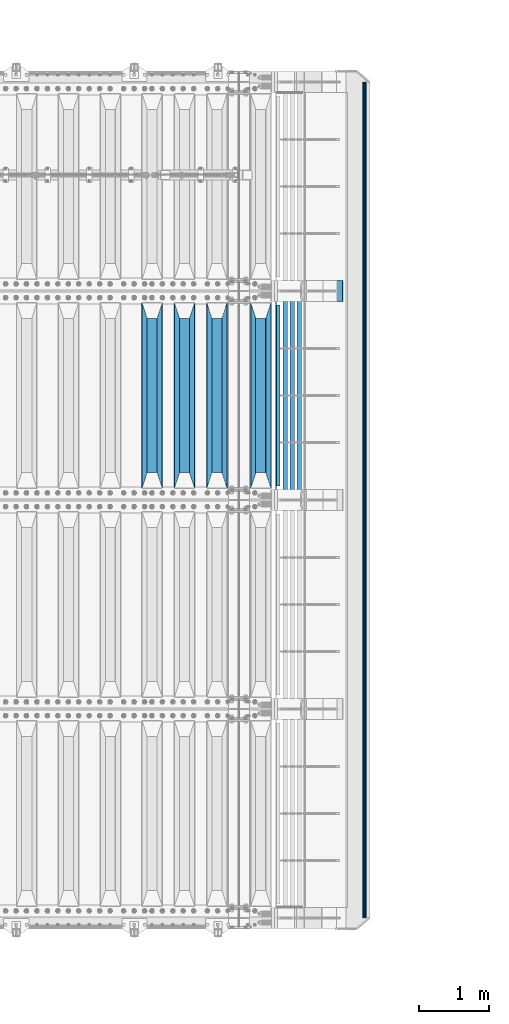
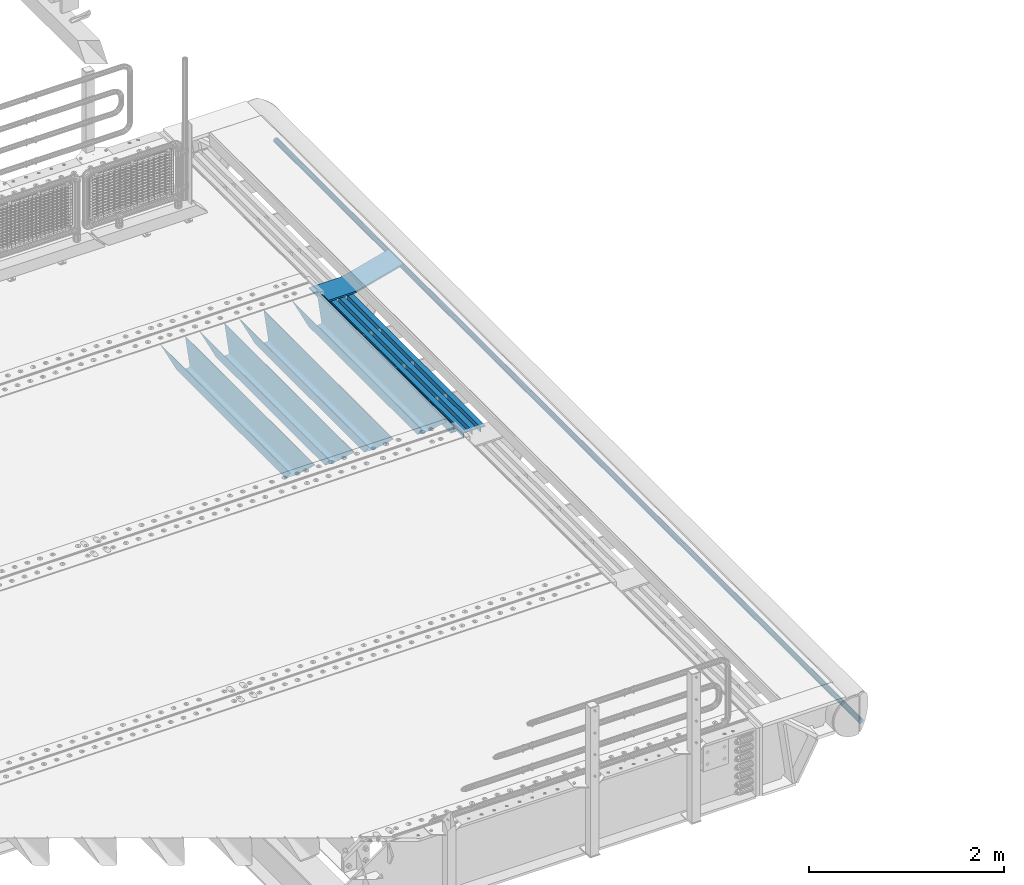
# One storey, part 133 of 257: 10 beams.
"""IFC2X3 building model written with IfcOpenShell, lengths in millimetres."""

from ifc_helpers import new_model, si_unit, frame, origin_with_axes, place, context, subcontext, project, spatial, faceted_brep, material, type_object, element, save


model = new_model("IFC2X3")

# Units and contexts
model_context = context("Model", 3, precision=1e-05, world=origin_with_axes())
body_context = subcontext(model_context, "Body", "Model", "MODEL_VIEW")
ifc_project = project(units=[si_unit("LENGTHUNIT", "METRE", prefix="MILLI"), si_unit("AREAUNIT", "SQUARE_METRE"), si_unit("VOLUMEUNIT", "CUBIC_METRE"), si_unit("MASSUNIT", "GRAM", prefix="KILO"), si_unit("TIMEUNIT", "SECOND"), si_unit("PLANEANGLEUNIT", "RADIAN"), si_unit("SOLIDANGLEUNIT", "STERADIAN"), si_unit("THERMODYNAMICTEMPERATUREUNIT", "DEGREE_CELSIUS"), si_unit("LUMINOUSINTENSITYUNIT", "LUMEN")], contexts=[model_context])

# Site, building, storey
site_placement = place(None, origin_with_axes())
site = spatial("IfcSite", under=ifc_project, at=site_placement, CompositionType="ELEMENT")
building_placement = place(site_placement, origin_with_axes())
building = spatial("IfcBuilding", under=site, at=building_placement, Name="Standard", CompositionType="ELEMENT")
storey_placement = place(building_placement, origin_with_axes())
storey = spatial("IfcBuildingStorey", under=building, at=storey_placement, Name="Undefined", CompositionType="ELEMENT", Elevation=0.0)

# Beams
ifc_material_1 = material(Name="STEEL/S355N")
beam_type_1 = type_object("IfcBeamType", PredefinedType="NOTDEFINED")
beam_1_placement = place(storey_placement, frame((59110.0, 6175.0, -115.0), z_axis=(0.0, 0.0, 1.0), x_axis=(0.0, 1.0, 0.0)))
element("IfcBeam", 1, at=beam_1_placement, inside=storey, type_object=beam_type_1, material=ifc_material_1, context=body_context, shape_type="Brep", body=[
    faceted_brep([(0.0, 150.0, 115.0), (0.0, 143.690000000002, 115.0), (2650.00000000297, 143.690000000002, 115.0), (2650.00000000297, 150.0, 115.0), (2650.00000000297, 142.059565218406, 110.0000000031), (2650.00000000297, 148.369565218403, 110.0000000031), (2441.90079219208, -80.1103600731149, -98.0992078077845), (2437.7588105432, -77.5672621345584, -102.241189456673), (2434.06523489746, -74.4080125315522, -105.934765102404), (2430.91086095089, -70.7102721255724, -109.089139048974), (2428.37322971128, -66.5649389910031, -111.626770288588), (2426.51472138055, -62.0739139532889, -113.485278619323), (2425.38102192091, -57.3475956567636, -114.618978078955), (2424.99999999987, -52.5021667386536, -115.0), (2424.99999999987, 52.5021667386536, -115.0), (2425.38102192091, 57.3475956567636, -114.618978078955), (2426.51472138055, 62.0739139532889, -113.485278619323), (2428.37322971128, 66.5649389910031, -111.626770288588), (2430.91086095089, 70.7102721255724, -109.089139048974), (2434.06523489746, 74.4080125315522, -105.934765102404), (2437.7588105432, 77.5672621345584, -102.241189456673), (2441.90079219208, 80.1103600731149, -98.0992078077846), (2446.38936140511, 81.9747917625791, -93.6106385947584), (2448.24948500409, 76.2713538057287, -91.7505149957729), (2444.62967112262, 74.76777986261, -95.3703288772456), (2441.28936334126, 72.7168944282894, -98.710636658607), (2438.31067330438, 70.1691124903809, -101.689326695487), (2435.76682334747, 67.1870637758839, -104.233176652398), (2433.72034654133, 63.8440531834931, -106.279653458539), (2432.22154950041, 60.2222587982324, -107.778450499454), (2431.30727574265, 56.4107117849126, -108.692724257221), (2430.99999999987, 52.5031078186876, -109.0), (2430.99999999987, -52.5031078186876, -109.0), (2431.30727574265, -56.4107117849126, -108.692724257221), (2432.22154950041, -60.2222587982324, -107.778450499454), (2433.72034654133, -63.8440531834931, -106.279653458539), (2435.76682334747, -67.1870637758839, -104.233176652398), (2438.31067330438, -70.1691124903809, -101.689326695487), (2441.28936334126, -72.7168944282894, -98.7106366586071), (2444.62967112262, -74.76777986261, -95.3703288772457), (2448.24948500409, -76.2713538057287, -91.7505149957729), (2650.00000000297, -142.059565218406, 110.0000000031), (2650.00000000297, -148.369565218403, 110.0000000031), (2446.38936140511, -81.9747917625791, -93.6106385947584), (2650.00000000297, -143.690000000002, 115.0), (2650.00000000297, -150.0, 115.0), (0.0, -143.690000000002, 115.0), (0.0, -150.0, 115.0), (0.0, -148.369565218258, 110.000000002662), (203.61063859742, -81.9747917625791, -93.6106385947584), (208.099207810447, -80.1103600731149, -98.0992078077845), (212.241189459335, -77.5672621345584, -102.241189456673), (215.934765105066, -74.4080125315522, -105.934765102404), (219.089139051636, -70.7102721255724, -109.089139048974), (221.626770291251, -66.5649389910031, -111.626770288588), (223.485278621985, -62.0739139532889, -113.485278619323), (224.618978081617, -57.3475956567636, -114.618978078955), (225.000000002662, -52.5021667386536, -115.0), (225.000000002662, 52.5021667386536, -115.0), (224.618978081617, 57.3475956567636, -114.618978078955), (223.485278621985, 62.0739139532889, -113.485278619323), (221.626770291251, 66.5649389910031, -111.626770288588), (219.089139051636, 70.7102721255724, -109.089139048974), (215.934765105066, 74.4080125315522, -105.934765102404), (212.241189459335, 77.5672621345584, -102.241189456673), (208.099207810447, 80.1103600731149, -98.0992078077846), (203.61063859742, 81.9747917625791, -93.6106385947584), (0.0, 148.369565218258, 110.000000002662), (0.0, 142.05956521826, 110.000000002662), (201.750514998435, 76.2713538057287, -91.7505149957729), (205.370328879908, 74.76777986261, -95.3703288772456), (208.710636661269, 72.7168944282894, -98.710636658607), (211.689326698149, 70.1691124903809, -101.689326695487), (214.233176655061, 67.1870637758839, -104.233176652398), (216.279653461201, 63.8440531834931, -106.279653458539), (217.778450502116, 60.2222587982324, -107.778450499454), (218.692724259884, 56.4107117849126, -108.692724257221), (219.000000002662, 52.5031078186876, -109.0), (219.000000002662, -52.5031078186876, -109.0), (218.692724259884, -56.4107117849126, -108.692724257221), (217.778450502116, -60.2222587982324, -107.778450499454), (216.279653461201, -63.8440531834931, -106.279653458539), (214.233176655061, -67.1870637758839, -104.233176652398), (211.689326698149, -70.1691124903809, -101.689326695487), (208.710636661269, -72.7168944282894, -98.7106366586071), (205.370328879908, -74.76777986261, -95.3703288772457), (201.750514998435, -76.2713538057287, -91.7505149957729), (0.0, -142.05956521826, 110.000000002662)], [[[0, 1, 2, 3]], [[3, 2, 4, 5]], [[6, 7, 8, 9, 10, 11, 12, 13, 14, 15, 16, 17, 18, 19, 20, 21, 22, 5, 4, 23, 24, 25, 26, 27, 28, 29, 30, 31, 32, 33, 34, 35, 36, 37, 38, 39, 40, 41, 42, 43]], [[44, 45, 42, 41]], [[46, 47, 45, 44]], [[43, 42, 45, 47, 48, 49]], [[6, 43, 49, 50]], [[7, 6, 50, 51]], [[8, 7, 51, 52]], [[9, 8, 52, 53]], [[10, 9, 53, 54]], [[11, 10, 54, 55]], [[12, 11, 55, 56]], [[13, 12, 56, 57]], [[14, 13, 57, 58]], [[15, 14, 58, 59]], [[16, 15, 59, 60]], [[17, 16, 60, 61]], [[18, 17, 61, 62]], [[19, 18, 62, 63]], [[20, 19, 63, 64]], [[21, 20, 64, 65]], [[22, 21, 65, 66]], [[0, 3, 5, 22, 66, 67]], [[1, 0, 67, 68]], [[23, 4, 2, 1, 68, 69]], [[24, 23, 69, 70]], [[25, 24, 70, 71]], [[26, 25, 71, 72]], [[27, 26, 72, 73]], [[28, 27, 73, 74]], [[29, 28, 74, 75]], [[30, 29, 75, 76]], [[31, 30, 76, 77]], [[32, 31, 77, 78]], [[33, 32, 78, 79]], [[34, 33, 79, 80]], [[35, 34, 80, 81]], [[36, 35, 81, 82]], [[37, 36, 82, 83]], [[38, 37, 83, 84]], [[39, 38, 84, 85]], [[40, 39, 85, 86]], [[46, 44, 41, 40, 86, 87]], [[47, 46, 87, 48]], [[86, 85, 84, 83, 82, 81, 80, 79, 78, 77, 76, 75, 74, 73, 72, 71, 70, 69, 68, 67, 66, 65, 64, 63, 62, 61, 60, 59, 58, 57, 56, 55, 54, 53, 52, 51, 50, 49, 48, 87]]]),
])
beam_2_placement = place(storey_placement, frame((58480.0, 6175.0, -115.0), z_axis=(0.0, 0.0, 1.0), x_axis=(0.0, 1.0, 0.0)))
element("IfcBeam", 2, at=beam_2_placement, inside=storey, type_object=beam_type_1, material=ifc_material_1, context=body_context, shape_type="Brep", body=[
    faceted_brep([(0.0, 150.0, 115.0), (0.0, 143.690000000002, 115.0), (2650.00000000297, 143.690000000002, 115.0), (2650.00000000297, 150.0, 115.0), (2650.00000000297, 142.059565218406, 110.0000000031), (2650.00000000297, 148.369565218403, 110.0000000031), (2441.90079219208, -80.1103600731149, -98.0992078077845), (2437.7588105432, -77.5672621345584, -102.241189456673), (2434.06523489746, -74.4080125315522, -105.934765102404), (2430.91086095089, -70.7102721255724, -109.089139048974), (2428.37322971128, -66.5649389910031, -111.626770288588), (2426.51472138055, -62.0739139532889, -113.485278619323), (2425.38102192091, -57.3475956567636, -114.618978078955), (2424.99999999987, -52.5021667386536, -115.0), (2424.99999999987, 52.5021667386536, -115.0), (2425.38102192091, 57.3475956567636, -114.618978078955), (2426.51472138055, 62.0739139532889, -113.485278619323), (2428.37322971128, 66.5649389910031, -111.626770288588), (2430.91086095089, 70.7102721255724, -109.089139048974), (2434.06523489746, 74.4080125315522, -105.934765102404), (2437.7588105432, 77.5672621345584, -102.241189456673), (2441.90079219208, 80.1103600731149, -98.0992078077846), (2446.38936140511, 81.9747917625791, -93.6106385947584), (2448.24948500409, 76.2713538057287, -91.7505149957729), (2444.62967112262, 74.76777986261, -95.3703288772456), (2441.28936334126, 72.7168944282894, -98.710636658607), (2438.31067330438, 70.1691124903809, -101.689326695487), (2435.76682334747, 67.1870637758839, -104.233176652398), (2433.72034654133, 63.8440531834931, -106.279653458539), (2432.22154950041, 60.2222587982324, -107.778450499454), (2431.30727574265, 56.4107117849126, -108.692724257221), (2430.99999999987, 52.5031078186876, -109.0), (2430.99999999987, -52.5031078186876, -109.0), (2431.30727574265, -56.4107117849126, -108.692724257221), (2432.22154950041, -60.2222587982324, -107.778450499454), (2433.72034654133, -63.8440531834931, -106.279653458539), (2435.76682334747, -67.1870637758839, -104.233176652398), (2438.31067330438, -70.1691124903809, -101.689326695487), (2441.28936334126, -72.7168944282894, -98.7106366586071), (2444.62967112262, -74.76777986261, -95.3703288772457), (2448.24948500409, -76.2713538057287, -91.7505149957729), (2650.00000000297, -142.059565218406, 110.0000000031), (2650.00000000297, -148.369565218403, 110.0000000031), (2446.38936140511, -81.9747917625791, -93.6106385947584), (2650.00000000297, -143.690000000002, 115.0), (2650.00000000297, -150.0, 115.0), (0.0, -143.690000000002, 115.0), (0.0, -150.0, 115.0), (0.0, -148.369565218258, 110.000000002662), (203.61063859742, -81.9747917625791, -93.6106385947584), (208.099207810447, -80.1103600731149, -98.0992078077845), (212.241189459335, -77.5672621345584, -102.241189456673), (215.934765105066, -74.4080125315522, -105.934765102404), (219.089139051636, -70.7102721255724, -109.089139048974), (221.626770291251, -66.5649389910031, -111.626770288588), (223.485278621985, -62.0739139532889, -113.485278619323), (224.618978081617, -57.3475956567636, -114.618978078955), (225.000000002662, -52.5021667386536, -115.0), (225.000000002662, 52.5021667386536, -115.0), (224.618978081617, 57.3475956567636, -114.618978078955), (223.485278621985, 62.0739139532889, -113.485278619323), (221.626770291251, 66.5649389910031, -111.626770288588), (219.089139051636, 70.7102721255724, -109.089139048974), (215.934765105066, 74.4080125315522, -105.934765102404), (212.241189459335, 77.5672621345584, -102.241189456673), (208.099207810447, 80.1103600731149, -98.0992078077846), (203.61063859742, 81.9747917625791, -93.6106385947584), (0.0, 148.369565218258, 110.000000002662), (0.0, 142.05956521826, 110.000000002662), (201.750514998435, 76.2713538057287, -91.7505149957729), (205.370328879908, 74.76777986261, -95.3703288772456), (208.710636661269, 72.7168944282894, -98.710636658607), (211.689326698149, 70.1691124903809, -101.689326695487), (214.233176655061, 67.1870637758839, -104.233176652398), (216.279653461201, 63.8440531834931, -106.279653458539), (217.778450502116, 60.2222587982324, -107.778450499454), (218.692724259884, 56.4107117849126, -108.692724257221), (219.000000002662, 52.5031078186876, -109.0), (219.000000002662, -52.5031078186876, -109.0), (218.692724259884, -56.4107117849126, -108.692724257221), (217.778450502116, -60.2222587982324, -107.778450499454), (216.279653461201, -63.8440531834931, -106.279653458539), (214.233176655061, -67.1870637758839, -104.233176652398), (211.689326698149, -70.1691124903809, -101.689326695487), (208.710636661269, -72.7168944282894, -98.7106366586071), (205.370328879908, -74.76777986261, -95.3703288772457), (201.750514998435, -76.2713538057287, -91.7505149957729), (0.0, -142.05956521826, 110.000000002662)], [[[0, 1, 2, 3]], [[3, 2, 4, 5]], [[6, 7, 8, 9, 10, 11, 12, 13, 14, 15, 16, 17, 18, 19, 20, 21, 22, 5, 4, 23, 24, 25, 26, 27, 28, 29, 30, 31, 32, 33, 34, 35, 36, 37, 38, 39, 40, 41, 42, 43]], [[44, 45, 42, 41]], [[46, 47, 45, 44]], [[43, 42, 45, 47, 48, 49]], [[6, 43, 49, 50]], [[7, 6, 50, 51]], [[8, 7, 51, 52]], [[9, 8, 52, 53]], [[10, 9, 53, 54]], [[11, 10, 54, 55]], [[12, 11, 55, 56]], [[13, 12, 56, 57]], [[14, 13, 57, 58]], [[15, 14, 58, 59]], [[16, 15, 59, 60]], [[17, 16, 60, 61]], [[18, 17, 61, 62]], [[19, 18, 62, 63]], [[20, 19, 63, 64]], [[21, 20, 64, 65]], [[22, 21, 65, 66]], [[0, 3, 5, 22, 66, 67]], [[1, 0, 67, 68]], [[23, 4, 2, 1, 68, 69]], [[24, 23, 69, 70]], [[25, 24, 70, 71]], [[26, 25, 71, 72]], [[27, 26, 72, 73]], [[28, 27, 73, 74]], [[29, 28, 74, 75]], [[30, 29, 75, 76]], [[31, 30, 76, 77]], [[32, 31, 77, 78]], [[33, 32, 78, 79]], [[34, 33, 79, 80]], [[35, 34, 80, 81]], [[36, 35, 81, 82]], [[37, 36, 82, 83]], [[38, 37, 83, 84]], [[39, 38, 84, 85]], [[40, 39, 85, 86]], [[46, 44, 41, 40, 86, 87]], [[47, 46, 87, 48]], [[86, 85, 84, 83, 82, 81, 80, 79, 78, 77, 76, 75, 74, 73, 72, 71, 70, 69, 68, 67, 66, 65, 64, 63, 62, 61, 60, 59, 58, 57, 56, 55, 54, 53, 52, 51, 50, 49, 48, 87]]]),
])
beam_3_placement = place(storey_placement, frame((58015.0, 6175.0, -115.0), z_axis=(0.0, 0.0, 1.0), x_axis=(0.0, 1.0, 0.0)))
element("IfcBeam", 3, at=beam_3_placement, inside=storey, type_object=beam_type_1, material=ifc_material_1, context=body_context, shape_type="Brep", body=[
    faceted_brep([(0.0, 150.0, 115.0), (0.0, 143.690000000002, 115.0), (2650.00000000297, 143.690000000002, 115.0), (2650.00000000297, 150.0, 115.0), (2650.00000000297, 142.059565218406, 110.0000000031), (2650.00000000297, 148.369565218403, 110.0000000031), (2441.90079219208, -80.1103600731149, -98.0992078077845), (2437.7588105432, -77.5672621345584, -102.241189456673), (2434.06523489746, -74.4080125315522, -105.934765102404), (2430.91086095089, -70.7102721255724, -109.089139048974), (2428.37322971128, -66.5649389910031, -111.626770288588), (2426.51472138055, -62.0739139532889, -113.485278619323), (2425.38102192091, -57.3475956567636, -114.618978078955), (2424.99999999987, -52.5021667386536, -115.0), (2424.99999999987, 52.5021667386536, -115.0), (2425.38102192091, 57.3475956567636, -114.618978078955), (2426.51472138055, 62.0739139532889, -113.485278619323), (2428.37322971128, 66.5649389910031, -111.626770288588), (2430.91086095089, 70.7102721255724, -109.089139048974), (2434.06523489746, 74.4080125315522, -105.934765102404), (2437.7588105432, 77.5672621345584, -102.241189456673), (2441.90079219208, 80.1103600731149, -98.0992078077846), (2446.38936140511, 81.9747917625791, -93.6106385947584), (2448.24948500409, 76.2713538057287, -91.7505149957729), (2444.62967112262, 74.76777986261, -95.3703288772456), (2441.28936334126, 72.7168944282894, -98.710636658607), (2438.31067330438, 70.1691124903809, -101.689326695487), (2435.76682334747, 67.1870637758839, -104.233176652398), (2433.72034654133, 63.8440531834931, -106.279653458539), (2432.22154950041, 60.2222587982324, -107.778450499454), (2431.30727574265, 56.4107117849126, -108.692724257221), (2430.99999999987, 52.5031078186876, -109.0), (2430.99999999987, -52.5031078186876, -109.0), (2431.30727574265, -56.4107117849126, -108.692724257221), (2432.22154950041, -60.2222587982324, -107.778450499454), (2433.72034654133, -63.8440531834931, -106.279653458539), (2435.76682334747, -67.1870637758839, -104.233176652398), (2438.31067330438, -70.1691124903809, -101.689326695487), (2441.28936334126, -72.7168944282894, -98.7106366586071), (2444.62967112262, -74.76777986261, -95.3703288772457), (2448.24948500409, -76.2713538057287, -91.7505149957729), (2650.00000000297, -142.059565218406, 110.0000000031), (2650.00000000297, -148.369565218403, 110.0000000031), (2446.38936140511, -81.9747917625791, -93.6106385947584), (2650.00000000297, -143.690000000002, 115.0), (2650.00000000297, -150.0, 115.0), (0.0, -143.690000000002, 115.0), (0.0, -150.0, 115.0), (0.0, -148.369565218258, 110.000000002662), (203.61063859742, -81.9747917625791, -93.6106385947584), (208.099207810447, -80.1103600731149, -98.0992078077845), (212.241189459335, -77.5672621345584, -102.241189456673), (215.934765105066, -74.4080125315522, -105.934765102404), (219.089139051636, -70.7102721255724, -109.089139048974), (221.626770291251, -66.5649389910031, -111.626770288588), (223.485278621985, -62.0739139532889, -113.485278619323), (224.618978081617, -57.3475956567636, -114.618978078955), (225.000000002662, -52.5021667386536, -115.0), (225.000000002662, 52.5021667386536, -115.0), (224.618978081617, 57.3475956567636, -114.618978078955), (223.485278621985, 62.0739139532889, -113.485278619323), (221.626770291251, 66.5649389910031, -111.626770288588), (219.089139051636, 70.7102721255724, -109.089139048974), (215.934765105066, 74.4080125315522, -105.934765102404), (212.241189459335, 77.5672621345584, -102.241189456673), (208.099207810447, 80.1103600731149, -98.0992078077846), (203.61063859742, 81.9747917625791, -93.6106385947584), (0.0, 148.369565218258, 110.000000002662), (0.0, 142.05956521826, 110.000000002662), (201.750514998435, 76.2713538057287, -91.7505149957729), (205.370328879908, 74.76777986261, -95.3703288772456), (208.710636661269, 72.7168944282894, -98.710636658607), (211.689326698149, 70.1691124903809, -101.689326695487), (214.233176655061, 67.1870637758839, -104.233176652398), (216.279653461201, 63.8440531834931, -106.279653458539), (217.778450502116, 60.2222587982324, -107.778450499454), (218.692724259884, 56.4107117849126, -108.692724257221), (219.000000002662, 52.5031078186876, -109.0), (219.000000002662, -52.5031078186876, -109.0), (218.692724259884, -56.4107117849126, -108.692724257221), (217.778450502116, -60.2222587982324, -107.778450499454), (216.279653461201, -63.8440531834931, -106.279653458539), (214.233176655061, -67.1870637758839, -104.233176652398), (211.689326698149, -70.1691124903809, -101.689326695487), (208.710636661269, -72.7168944282894, -98.7106366586071), (205.370328879908, -74.76777986261, -95.3703288772457), (201.750514998435, -76.2713538057287, -91.7505149957729), (0.0, -142.05956521826, 110.000000002662)], [[[0, 1, 2, 3]], [[3, 2, 4, 5]], [[6, 7, 8, 9, 10, 11, 12, 13, 14, 15, 16, 17, 18, 19, 20, 21, 22, 5, 4, 23, 24, 25, 26, 27, 28, 29, 30, 31, 32, 33, 34, 35, 36, 37, 38, 39, 40, 41, 42, 43]], [[44, 45, 42, 41]], [[46, 47, 45, 44]], [[43, 42, 45, 47, 48, 49]], [[6, 43, 49, 50]], [[7, 6, 50, 51]], [[8, 7, 51, 52]], [[9, 8, 52, 53]], [[10, 9, 53, 54]], [[11, 10, 54, 55]], [[12, 11, 55, 56]], [[13, 12, 56, 57]], [[14, 13, 57, 58]], [[15, 14, 58, 59]], [[16, 15, 59, 60]], [[17, 16, 60, 61]], [[18, 17, 61, 62]], [[19, 18, 62, 63]], [[20, 19, 63, 64]], [[21, 20, 64, 65]], [[22, 21, 65, 66]], [[0, 3, 5, 22, 66, 67]], [[1, 0, 67, 68]], [[23, 4, 2, 1, 68, 69]], [[24, 23, 69, 70]], [[25, 24, 70, 71]], [[26, 25, 71, 72]], [[27, 26, 72, 73]], [[28, 27, 73, 74]], [[29, 28, 74, 75]], [[30, 29, 75, 76]], [[31, 30, 76, 77]], [[32, 31, 77, 78]], [[33, 32, 78, 79]], [[34, 33, 79, 80]], [[35, 34, 80, 81]], [[36, 35, 81, 82]], [[37, 36, 82, 83]], [[38, 37, 83, 84]], [[39, 38, 84, 85]], [[40, 39, 85, 86]], [[46, 44, 41, 40, 86, 87]], [[47, 46, 87, 48]], [[86, 85, 84, 83, 82, 81, 80, 79, 78, 77, 76, 75, 74, 73, 72, 71, 70, 69, 68, 67, 66, 65, 64, 63, 62, 61, 60, 59, 58, 57, 56, 55, 54, 53, 52, 51, 50, 49, 48, 87]]]),
])
beam_4_placement = place(storey_placement, frame((57550.0, 6175.0, -115.0), z_axis=(0.0, 0.0, 1.0), x_axis=(0.0, 1.0, 0.0)))
element("IfcBeam", 4, at=beam_4_placement, inside=storey, type_object=beam_type_1, material=ifc_material_1, context=body_context, shape_type="Brep", body=[
    faceted_brep([(0.0, 150.0, 115.0), (0.0, 143.690000000002, 115.0), (2650.00000000297, 143.690000000002, 115.0), (2650.00000000297, 150.0, 115.0), (2650.00000000297, 142.059565218406, 110.0000000031), (2650.00000000297, 148.369565218403, 110.0000000031), (2441.90079219208, -80.1103600731149, -98.0992078077845), (2437.7588105432, -77.5672621345584, -102.241189456673), (2434.06523489746, -74.4080125315522, -105.934765102404), (2430.91086095089, -70.7102721255724, -109.089139048974), (2428.37322971128, -66.5649389910031, -111.626770288588), (2426.51472138055, -62.0739139532889, -113.485278619323), (2425.38102192091, -57.3475956567636, -114.618978078955), (2424.99999999987, -52.5021667386536, -115.0), (2424.99999999987, 52.5021667386536, -115.0), (2425.38102192091, 57.3475956567636, -114.618978078955), (2426.51472138055, 62.0739139532889, -113.485278619323), (2428.37322971128, 66.5649389910031, -111.626770288588), (2430.91086095089, 70.7102721255724, -109.089139048974), (2434.06523489746, 74.4080125315522, -105.934765102404), (2437.7588105432, 77.5672621345584, -102.241189456673), (2441.90079219208, 80.1103600731149, -98.0992078077846), (2446.38936140511, 81.9747917625791, -93.6106385947584), (2448.24948500409, 76.2713538057287, -91.7505149957729), (2444.62967112262, 74.76777986261, -95.3703288772456), (2441.28936334126, 72.7168944282894, -98.710636658607), (2438.31067330438, 70.1691124903809, -101.689326695487), (2435.76682334747, 67.1870637758839, -104.233176652398), (2433.72034654133, 63.8440531834931, -106.279653458539), (2432.22154950041, 60.2222587982324, -107.778450499454), (2431.30727574265, 56.4107117849126, -108.692724257221), (2430.99999999987, 52.5031078186876, -109.0), (2430.99999999987, -52.5031078186876, -109.0), (2431.30727574265, -56.4107117849126, -108.692724257221), (2432.22154950041, -60.2222587982324, -107.778450499454), (2433.72034654133, -63.8440531834931, -106.279653458539), (2435.76682334747, -67.1870637758839, -104.233176652398), (2438.31067330438, -70.1691124903809, -101.689326695487), (2441.28936334126, -72.7168944282894, -98.7106366586071), (2444.62967112262, -74.76777986261, -95.3703288772457), (2448.24948500409, -76.2713538057287, -91.7505149957729), (2650.00000000297, -142.059565218406, 110.0000000031), (2650.00000000297, -148.369565218403, 110.0000000031), (2446.38936140511, -81.9747917625791, -93.6106385947584), (2650.00000000297, -143.690000000002, 115.0), (2650.00000000297, -150.0, 115.0), (0.0, -143.690000000002, 115.0), (0.0, -150.0, 115.0), (0.0, -148.369565218258, 110.000000002662), (203.61063859742, -81.9747917625791, -93.6106385947584), (208.099207810447, -80.1103600731149, -98.0992078077845), (212.241189459335, -77.5672621345584, -102.241189456673), (215.934765105066, -74.4080125315522, -105.934765102404), (219.089139051636, -70.7102721255724, -109.089139048974), (221.626770291251, -66.5649389910031, -111.626770288588), (223.485278621985, -62.0739139532889, -113.485278619323), (224.618978081617, -57.3475956567636, -114.618978078955), (225.000000002662, -52.5021667386536, -115.0), (225.000000002662, 52.5021667386536, -115.0), (224.618978081617, 57.3475956567636, -114.618978078955), (223.485278621985, 62.0739139532889, -113.485278619323), (221.626770291251, 66.5649389910031, -111.626770288588), (219.089139051636, 70.7102721255724, -109.089139048974), (215.934765105066, 74.4080125315522, -105.934765102404), (212.241189459335, 77.5672621345584, -102.241189456673), (208.099207810447, 80.1103600731149, -98.0992078077846), (203.61063859742, 81.9747917625791, -93.6106385947584), (0.0, 148.369565218258, 110.000000002662), (0.0, 142.05956521826, 110.000000002662), (201.750514998435, 76.2713538057287, -91.7505149957729), (205.370328879908, 74.76777986261, -95.3703288772456), (208.710636661269, 72.7168944282894, -98.710636658607), (211.689326698149, 70.1691124903809, -101.689326695487), (214.233176655061, 67.1870637758839, -104.233176652398), (216.279653461201, 63.8440531834931, -106.279653458539), (217.778450502116, 60.2222587982324, -107.778450499454), (218.692724259884, 56.4107117849126, -108.692724257221), (219.000000002662, 52.5031078186876, -109.0), (219.000000002662, -52.5031078186876, -109.0), (218.692724259884, -56.4107117849126, -108.692724257221), (217.778450502116, -60.2222587982324, -107.778450499454), (216.279653461201, -63.8440531834931, -106.279653458539), (214.233176655061, -67.1870637758839, -104.233176652398), (211.689326698149, -70.1691124903809, -101.689326695487), (208.710636661269, -72.7168944282894, -98.7106366586071), (205.370328879908, -74.76777986261, -95.3703288772457), (201.750514998435, -76.2713538057287, -91.7505149957729), (0.0, -142.05956521826, 110.000000002662)], [[[0, 1, 2, 3]], [[3, 2, 4, 5]], [[6, 7, 8, 9, 10, 11, 12, 13, 14, 15, 16, 17, 18, 19, 20, 21, 22, 5, 4, 23, 24, 25, 26, 27, 28, 29, 30, 31, 32, 33, 34, 35, 36, 37, 38, 39, 40, 41, 42, 43]], [[44, 45, 42, 41]], [[46, 47, 45, 44]], [[43, 42, 45, 47, 48, 49]], [[6, 43, 49, 50]], [[7, 6, 50, 51]], [[8, 7, 51, 52]], [[9, 8, 52, 53]], [[10, 9, 53, 54]], [[11, 10, 54, 55]], [[12, 11, 55, 56]], [[13, 12, 56, 57]], [[14, 13, 57, 58]], [[15, 14, 58, 59]], [[16, 15, 59, 60]], [[17, 16, 60, 61]], [[18, 17, 61, 62]], [[19, 18, 62, 63]], [[20, 19, 63, 64]], [[21, 20, 64, 65]], [[22, 21, 65, 66]], [[0, 3, 5, 22, 66, 67]], [[1, 0, 67, 68]], [[23, 4, 2, 1, 68, 69]], [[24, 23, 69, 70]], [[25, 24, 70, 71]], [[26, 25, 71, 72]], [[27, 26, 72, 73]], [[28, 27, 73, 74]], [[29, 28, 74, 75]], [[30, 29, 75, 76]], [[31, 30, 76, 77]], [[32, 31, 77, 78]], [[33, 32, 78, 79]], [[34, 33, 79, 80]], [[35, 34, 80, 81]], [[36, 35, 81, 82]], [[37, 36, 82, 83]], [[38, 37, 83, 84]], [[39, 38, 84, 85]], [[40, 39, 85, 86]], [[46, 44, 41, 40, 86, 87]], [[47, 46, 87, 48]], [[86, 85, 84, 83, 82, 81, 80, 79, 78, 77, 76, 75, 74, 73, 72, 71, 70, 69, 68, 67, 66, 65, 64, 63, 62, 61, 60, 59, 58, 57, 56, 55, 54, 53, 52, 51, 50, 49, 48, 87]]]),
])
ifc_material_2 = material(Name="STEEL/S355J2")
beam_type_2 = type_object("IfcBeamType", PredefinedType="NOTDEFINED")
beam_5_placement = place(storey_placement, frame((59354.5025260065, 6150.0, -124.999999999985), z_axis=(0.0, 0.0, 1.0), x_axis=(0.0, 1.0, 0.0)))
element("IfcBeam", 5, at=beam_5_placement, inside=storey, type_object=beam_type_2, material=ifc_material_2, context=body_context, shape_type="Brep", body=[
    faceted_brep([(2700.0, 22.5, -15.0), (2684.54915028125, 22.5, -17.4471741852423), (2684.54915028125, 32.5, -17.4471741852423), (2700.0, 32.5, -15.0), (2670.61073738538, 22.5, -24.5491502812526), (2670.61073738538, 32.5, -24.5491502812526), (2659.54915028125, 22.5, -35.6107373853764), (2659.54915028125, 32.5, -35.6107373853764), (2652.44717418524, 22.5, -49.5491502812526), (2652.44717418524, 32.5, -49.5491502812526), (2651.58384440325, -32.5, -55.0), (2650.0, -32.5, -65.0), (2650.0, 32.5, -65.0), (2651.58384440325, 22.5, -55.0), (0.0, 32.5, 65.0), (0.0, 22.5, 65.0), (2700.0, 22.5, 65.0), (2700.0, 32.5, 65.0), (0.0, 32.5, -15.0), (0.0, 22.5, -15.0), (15.4508497187474, 32.5, -17.4471741852423), (15.4508497187474, 22.5, -17.4471741852423), (29.3892626146236, 32.5, -24.5491502812526), (29.3892626146236, 22.5, -24.5491502812526), (40.4508497187473, 32.5, -35.6107373853763), (40.4508497187473, 22.5, -35.6107373853763), (47.5528258147577, 32.5, -49.5491502812526), (47.5528258147577, 22.5, -49.5491502812526), (50.0, -32.5, -65.0), (48.4161555967548, -32.5, -55.0), (48.4161555967548, 22.5, -55.0), (50.0, 32.5, -65.0)], [[[0, 1, 2, 3]], [[4, 5, 2, 1]], [[6, 7, 5, 4]], [[8, 9, 7, 6]], [[10, 11, 12, 9, 8, 13]], [[14, 15, 16, 17]], [[15, 14, 18, 19]], [[19, 18, 20, 21]], [[21, 20, 22, 23]], [[23, 22, 24, 25]], [[25, 24, 26, 27]], [[28, 29, 30, 27, 26, 31]], [[30, 29, 10, 13]], [[16, 15, 19, 21, 23, 25, 27, 30, 13, 8, 6, 4, 1, 0]], [[17, 16, 0, 3]], [[5, 7, 9, 12, 31, 26, 24, 22, 20, 18, 14, 17, 3, 2]], [[28, 31, 12, 11]], [[29, 28, 11, 10]]]),
])
beam_type_3 = type_object("IfcBeamType", PredefinedType="NOTDEFINED")
beam_6_placement = place(storey_placement, frame((59346.9988298906, 9000.0, -169.999999999995), z_axis=(0.0, -1.0, 0.0), x_axis=(1.0, 0.0, 0.0)))
element("IfcBeam", 6, at=beam_6_placement, inside=storey, type_object=beam_type_3, material=ifc_material_1, context=body_context, shape_type="Brep", body=[
    faceted_brep([(0.0, 10.0, -150.0), (0.0, 10.0, 150.0), (356.495387467709, 10.0, 150.0), (356.495387467709, 10.0000000000045, -150.0), (0.0, -10.0, 150.0), (0.0, -10.0, -150.0), (356.495387467709, -10.0, -150.0), (356.495387467709, -10.0, 150.0), (382.770279632619, 11.7334369042663, 150.0), (382.770279632619, 11.7334369042663, -150.0), (385.397768849085, -8.09321940530714, -150.0), (385.397768849085, -8.09321940530714, 150.0), (413.799145685371, -2.4059304593832, -150.0), (413.799145685371, -2.4059304593832, 150.0), (408.589713120156, 16.9036995823731, 150.0), (408.589713119858, 16.9036995827009, -150.0), (938.999999999978, 160.0, 150.0), (938.999999999978, 160.0, -150.0), (944.209432565192, 140.69036995827, 150.0), (944.209432565192, 140.69036995827, -150.0)], [[[0, 1, 2, 3]], [[4, 5, 6, 7]], [[5, 4, 1, 0]], [[3, 2, 8, 9]], [[7, 6, 10, 11]], [[10, 12, 13, 11]], [[8, 14, 15, 9]], [[15, 14, 16, 17]], [[14, 8, 2, 1, 4, 7, 11, 13, 18, 16]], [[13, 12, 19, 18]], [[12, 10, 6, 5, 0, 3, 9, 15, 17, 19]], [[18, 19, 17, 16]]]),
])
beam_type_4 = type_object("IfcBeamType", PredefinedType="NOTDEFINED")
for number, where, z_axis, x_axis in (
    (7, (59662.0025260169, 8869.9999003886, -209.999999999563), (0.0, 0.0, -1.0), (0.0, -1.0, 0.0)),
    (8, (59562.0025260169, 8869.99990038863, -209.999999999563), (0.0, 0.0, -1.0), (0.0, -1.0, 0.0)),
    (9, (59462.0025260162, 8870.00000231317, -209.999999999622), (0.0, 0.0, -1.0), (0.0, -1.0, 0.0)),
):
    element("IfcBeam", number, at=place(storey_placement, frame(where, z_axis=z_axis, x_axis=x_axis)), inside=storey, type_object=beam_type_4, material=ifc_material_2, context=body_context, shape_type="Brep", body=[
        faceted_brep([(-9.09494701772928e-13, 29.9999999999854, -29.9999999999999), (-9.09494701772928e-13, 29.9999999999854, 30.0000000000001), (2740.00017042501, 29.9999999999854, 30.0000000000001), (2740.00017042501, 29.9999999999854, -29.9999999999999), (-9.09494701772928e-13, 23.9999999999854, 30.0), (2740.00017042501, 23.9999999999854, 30.0), (-1.81898940354586e-12, 23.9999999999854, -24.0), (2740.00017042501, 23.9999999999854, -24.0), (-1.81898940354586e-12, -30.0000000000146, -24.0), (2740.00017042501, -30.0000000000146, -24.0), (-1.81898940354586e-12, -30.0000000000146, -30.0), (2740.00017042501, -30.0000000000146, -30.0)], [[[0, 1, 2, 3]], [[1, 4, 5, 2]], [[4, 6, 7, 5]], [[6, 8, 9, 7]], [[8, 10, 11, 9]], [[10, 0, 3, 11]], [[5, 7, 9, 11, 3, 2]], [[10, 8, 6, 4, 1, 0]]]),
    ])
beam_type_5 = type_object("IfcBeamType", Name="D60", PredefinedType="NOTDEFINED")
beam_7_placement = place(storey_placement, frame((60596.7525260065, 6.5369931689923e-15, -478.0), z_axis=(0.0, 0.0, 1.0), x_axis=(0.0, 1.0, 0.0)))
element("IfcBeam", 10, at=beam_7_placement, inside=storey, type_object=beam_type_5, material=ifc_material_1, ObjectType="D60", context=body_context, shape_type="Brep", body=[
    faceted_brep([(0.0, -29.9999999999927, 0.0), (3.46944695195361e-18, -27.7163859753273, -11.4805029709527), (12000.0000000006, -27.7163859753273, -11.4805029709527), (12000.0000000006, -29.9999999999927, 0.0), (0.0, -21.2132034355891, -21.2132034355964), (12000.0000000006, -21.2132034355891, -21.2132034355964), (0.0, -11.480502970946, -27.7163859753386), (12000.0000000006, -11.480502970946, -27.7163859753386), (0.0, 7.27595761418343e-12, -30.0), (12000.0000000006, 7.27595761418343e-12, -30.0), (0.0, 11.4805029709605, -27.7163859753386), (12000.0000000006, 11.4805029709605, -27.7163859753386), (0.0, 21.2132034356036, -21.2132034355964), (12000.0000000006, 21.2132034356036, -21.2132034355964), (0.0, 27.7163859753346, -11.4805029709527), (12000.0000000006, 27.7163859753346, -11.4805029709527), (0.0, 30.0, 0.0), (12000.0000000006, 30.0, 0.0), (0.0, 27.7163859753346, 11.4805029709527), (12000.0000000006, 27.7163859753346, 11.4805029709527), (0.0, 21.2132034356036, 21.2132034355964), (12000.0000000006, 21.2132034356036, 21.2132034355964), (0.0, 11.4805029709605, 27.7163859753386), (12000.0000000006, 11.4805029709605, 27.7163859753386), (0.0, 7.27595761418343e-12, 30.0), (12000.0000000006, 7.27595761418343e-12, 30.0), (0.0, -11.480502970946, 27.7163859753386), (12000.0000000006, -11.480502970946, 27.7163859753386), (0.0, -21.2132034355891, 21.2132034355964), (12000.0000000006, -21.2132034355891, 21.2132034355964), (3.46944695195361e-18, -27.7163859753273, 11.4805029709527), (12000.0000000006, -27.7163859753273, 11.4805029709527)], [[[0, 1, 2, 3]], [[1, 4, 5, 2]], [[4, 6, 7, 5]], [[6, 8, 9, 7]], [[8, 10, 11, 9]], [[10, 12, 13, 11]], [[12, 14, 15, 13]], [[14, 16, 17, 15]], [[16, 18, 19, 17]], [[18, 20, 21, 19]], [[20, 22, 23, 21]], [[22, 24, 25, 23]], [[24, 26, 27, 25]], [[26, 28, 29, 27]], [[28, 30, 31, 29]], [[30, 0, 3, 31]], [[5, 7, 9, 11, 13, 15, 17, 19, 21, 23, 25, 27, 29, 31, 3, 2]], [[30, 28, 26, 24, 22, 20, 18, 16, 14, 12, 10, 8, 6, 4, 1, 0]]]),
])

save(model, "model.ifc")
